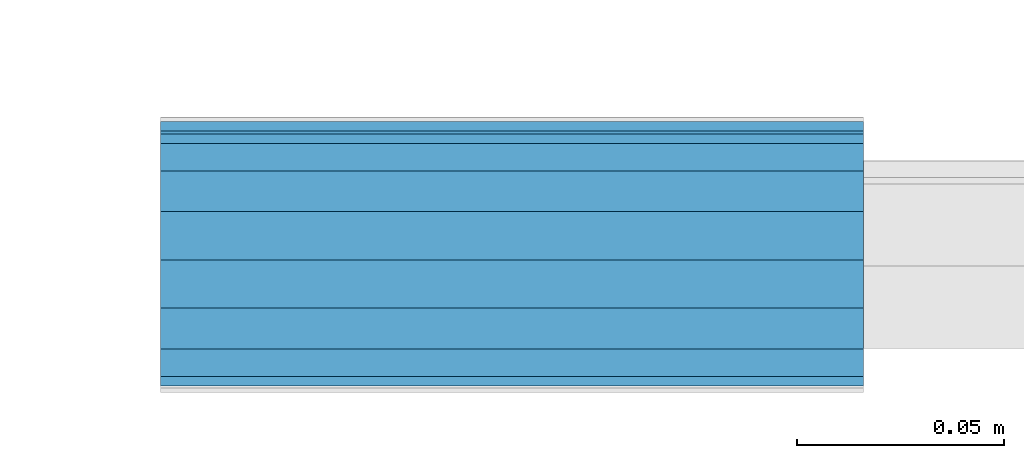
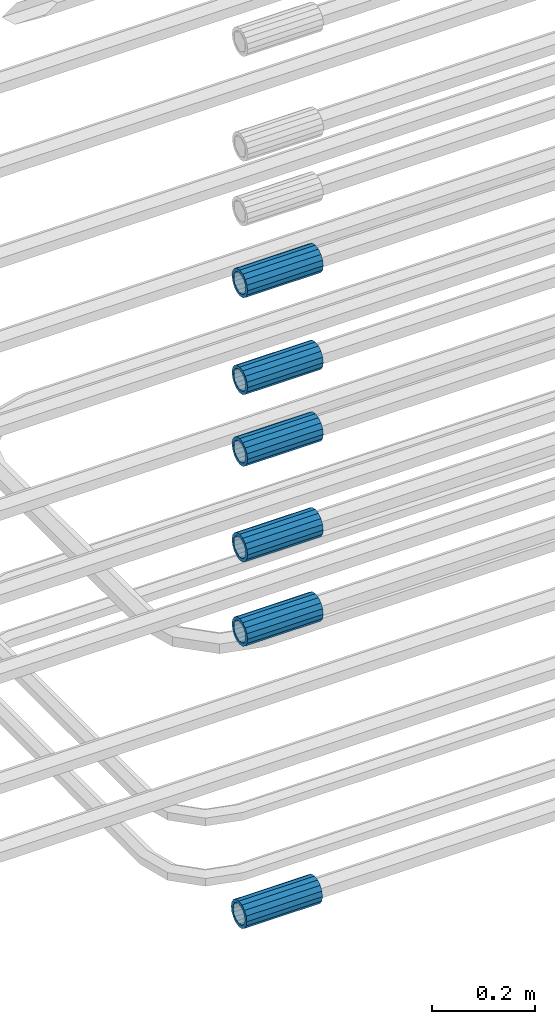
# One storey, part 4 of 119: 6 beams.
"""IFC2X3 building model written with IfcOpenShell, lengths in millimetres."""

from ifc_helpers import new_model, si_unit, frame, origin_with_axes, place, context, subcontext, project, spatial, faceted_brep, material, type_object, element, save


model = new_model("IFC2X3")

# Units and contexts
model_context = context("Model", 3, precision=1e-05, world=origin_with_axes())
body_context = subcontext(model_context, "Body", "Model", "MODEL_VIEW")
ifc_project = project(units=[si_unit("LENGTHUNIT", "METRE", prefix="MILLI"), si_unit("AREAUNIT", "SQUARE_METRE"), si_unit("VOLUMEUNIT", "CUBIC_METRE"), si_unit("MASSUNIT", "GRAM", prefix="KILO"), si_unit("TIMEUNIT", "SECOND"), si_unit("PLANEANGLEUNIT", "RADIAN"), si_unit("SOLIDANGLEUNIT", "STERADIAN"), si_unit("THERMODYNAMICTEMPERATUREUNIT", "DEGREE_CELSIUS"), si_unit("LUMINOUSINTENSITYUNIT", "LUMEN")], contexts=[model_context])

# Site, building, storey
site_placement = place(None, origin_with_axes())
site = spatial("IfcSite", under=ifc_project, at=site_placement, CompositionType="ELEMENT")
building_placement = place(site_placement, origin_with_axes())
building = spatial("IfcBuilding", under=site, at=building_placement, Name="Undefined", CompositionType="ELEMENT")
storey_placement = place(building_placement, origin_with_axes())
storey = spatial("IfcBuildingStorey", under=building, at=storey_placement, Name="Undefined", CompositionType="ELEMENT", Elevation=0.0)

# Beams
ifc_material = material(Name="STEEL/S275")
beam_type = type_object("IfcBeamType", PredefinedType="NOTDEFINED")
beam_1_placement = place(storey_placement, frame((2029920.00007889, 6205101.97994599, 19088.9893060828), z_axis=(0.0, 0.0, 1.0), x_axis=(-0.99999999999998, 1.98000110685822e-07, 0.0)))
element("IfcBeam", 1, at=beam_1_placement, inside=storey, type_object=beam_type, material=ifc_material, Name="AG40N", context=body_context, shape_type="Brep", body=[
    faceted_brep([(1.62981450557709e-09, -23.4999999990687, 0.0), (7.45058059692383e-09, -21.7111690142192, 8.99306066057534), (170.000002125278, -21.711168999318, 8.99306066022245), (170.000002127141, -23.4999999844003, -3.66071617463604e-10), (4.65661287307739e-09, -16.6170093587134, 16.6170093578889), (170.000002122484, -16.6170093440451, 16.6170093575288), (1.86264514923096e-09, -8.99306066217832, 21.7111690140277), (170.000002118759, -8.99306064750999, 21.7111690136603), (2.3283064365387e-10, 9.31322574615479e-10, 23.5), (170.000002114102, 1.28056854009628e-08, 23.4999999996485), (-6.51925802230835e-09, 8.99306065868586, 21.7111690140241), (170.00000211224, 8.99306067335419, 21.7111690136639), (-7.45058059692383e-09, 16.6170093561523, 16.6170093578853), (170.000002109446, 16.6170093708206, 16.6170093575324), (-9.31322574615479e-09, 21.711169013055, 8.99306066057534), (170.000002108514, 21.7111690277234, 8.99306066022245), (-1.16415321826935e-09, 23.5000000009313, 0.0), (170.000002108514, 23.5000000144355, -3.66071617463604e-10), (-8.38190317153931e-09, 21.7111690151505, -8.99306066059444), (170.000002110377, 21.7111690300517, -8.9930606609546), (-5.58793544769287e-09, 16.6170093598776, -16.6170093579008), (170.000002113171, 16.6170093745459, -16.6170093582609), (-9.31322574615479e-10, 8.99306066334248, -21.7111690140396), (170.000002115965, 8.99306067801081, -21.7111690143961), (2.3283064365387e-10, 9.31322574615479e-10, -23.5), (170.00000211969, 1.7927959561348e-08, -23.5000000003843), (5.58793544769287e-09, -8.99306065752171, -21.7111690140396), (170.000002123415, -8.99306064285338, -21.7111690143961), (8.38190317153931e-09, -16.6170093549881, -16.6170093579008), (170.000002125278, -16.6170093403198, -16.6170093582646), (9.31322574615479e-09, -21.7111690121237, -8.99306066059444), (170.000002127141, -21.7111689972226, -8.9930606609546), (1.11758708953857e-08, -30.4999999990687, -9.54969436861575e-12), (1.30385160446167e-08, -28.1783257392235, -11.6718446871514), (170.000002129003, -28.1783257243223, -11.6718446875116), (170.000002129935, -30.4999999841675, -3.66071617463604e-10), (1.02445483207703e-08, -21.5667568228673, -21.5667568262129), (170.000002128072, -21.566756808199, -21.5667568265694), (7.45058059692383e-09, -11.6718446831219, -28.1783257416196), (170.000002125278, -11.6718446684536, -28.1783257419834), (3.72529029846191e-09, 3.95812094211578e-09, -30.5000000000277), (170.00000211969, 1.83936208486557e-08, -30.5000000003879), (-9.31322574615479e-10, 11.6718446905725, -28.1783257416232), (170.000002115965, 11.6718447052408, -28.1783257419797), (-6.51925802230835e-09, 21.5667568286881, -21.5667568262093), (170.000002110377, 21.5667568433564, -21.5667568265694), (-9.31322574615479e-09, 28.178325742716, -11.6718446871478), (170.000002108514, 28.1783257573843, -11.6718446875079), (-1.21071934700012e-08, 30.5, -5.91171556152403e-12), (170.000002106652, 30.5000000144355, -3.62433638656512e-10), (-1.21071934700012e-08, 28.1783257401548, 11.6718446871359), (170.00000210572, 28.1783257548232, 11.6718446867794), (-1.02445483207703e-08, 21.5667568240315, 21.5667568261974), (170.000002107583, 21.566756838467, 21.5667568258409), (-7.45058059692383e-09, 11.671844684286, 28.1783257416041), (170.000002110377, 11.6718446989544, 28.178325741244), (-2.79396772384644e-09, -2.56113708019257e-09, 30.5000000000159), (170.000002114102, 1.18743628263474e-08, 30.4999999996558), (1.86264514923096e-09, -11.6718446896411, 28.1783257416114), (170.000002118759, -11.67184467474, 28.178325741244), (7.45058059692383e-09, -21.5667568275239, 21.5667568261974), (170.000002123415, -21.5667568126228, 21.5667568258373), (1.02445483207703e-08, -28.1783257415518, 11.6718446871359), (170.000002127141, -28.1783257271163, 11.6718446867794)], [[[0, 1, 2, 3]], [[1, 4, 5, 2]], [[4, 6, 7, 5]], [[6, 8, 9, 7]], [[8, 10, 11, 9]], [[10, 12, 13, 11]], [[12, 14, 15, 13]], [[14, 16, 17, 15]], [[16, 18, 19, 17]], [[18, 20, 21, 19]], [[20, 22, 23, 21]], [[22, 24, 25, 23]], [[24, 26, 27, 25]], [[26, 28, 29, 27]], [[28, 30, 31, 29]], [[30, 0, 3, 31]], [[32, 33, 34, 35]], [[33, 36, 37, 34]], [[36, 38, 39, 37]], [[38, 40, 41, 39]], [[40, 42, 43, 41]], [[42, 44, 45, 43]], [[44, 46, 47, 45]], [[46, 48, 49, 47]], [[48, 50, 51, 49]], [[50, 52, 53, 51]], [[52, 54, 55, 53]], [[54, 56, 57, 55]], [[56, 58, 59, 57]], [[58, 60, 61, 59]], [[60, 62, 63, 61]], [[62, 32, 35, 63]], [[37, 39, 41, 43, 45, 47, 49, 51, 53, 55, 57, 59, 61, 63, 35, 34], [5, 7, 9, 11, 13, 15, 17, 19, 21, 23, 25, 27, 29, 31, 3, 2]], [[62, 60, 58, 56, 54, 52, 50, 48, 46, 44, 42, 40, 38, 36, 33, 32], [30, 28, 26, 24, 22, 20, 18, 16, 14, 12, 10, 8, 6, 4, 1, 0]]]),
])
beam_2_placement = place(storey_placement, frame((2029920.00007889, 6205098.98994599, 19760.9893052823), z_axis=(0.0, 0.0, 1.0), x_axis=(-0.99999999999998, 1.98000110685822e-07, 0.0)))
element("IfcBeam", 2, at=beam_2_placement, inside=storey, type_object=beam_type, material=ifc_material, Name="AG40N", context=body_context, shape_type="Brep", body=[
    faceted_brep([(1.62981450557709e-09, -23.4999999990687, 0.0), (7.45058059692383e-09, -21.7111690142192, 8.99306066057534), (170.000002125278, -21.711168999318, 8.99306066022245), (170.000002127141, -23.4999999844003, -3.66071617463604e-10), (4.65661287307739e-09, -16.6170093587134, 16.6170093578889), (170.000002122484, -16.6170093440451, 16.6170093575288), (1.86264514923096e-09, -8.99306066217832, 21.7111690140277), (170.000002118759, -8.99306064750999, 21.7111690136603), (2.3283064365387e-10, 9.31322574615479e-10, 23.5), (170.000002114102, 1.28056854009628e-08, 23.4999999996485), (-6.51925802230835e-09, 8.99306065868586, 21.7111690140241), (170.00000211224, 8.99306067335419, 21.7111690136639), (-7.45058059692383e-09, 16.6170093561523, 16.6170093578853), (170.000002109446, 16.6170093708206, 16.6170093575324), (-9.31322574615479e-09, 21.711169013055, 8.99306066057534), (170.000002108514, 21.7111690277234, 8.99306066022245), (-1.16415321826935e-09, 23.5000000009313, 0.0), (170.000002108514, 23.5000000144355, -3.66071617463604e-10), (-8.38190317153931e-09, 21.7111690151505, -8.99306066059444), (170.000002110377, 21.7111690300517, -8.9930606609546), (-5.58793544769287e-09, 16.6170093598776, -16.6170093579008), (170.000002113171, 16.6170093745459, -16.6170093582609), (-9.31322574615479e-10, 8.99306066334248, -21.7111690140396), (170.000002115965, 8.99306067801081, -21.7111690143961), (2.3283064365387e-10, 9.31322574615479e-10, -23.5), (170.00000211969, 1.7927959561348e-08, -23.5000000003843), (5.58793544769287e-09, -8.99306065752171, -21.7111690140396), (170.000002123415, -8.99306064285338, -21.7111690143961), (8.38190317153931e-09, -16.6170093549881, -16.6170093579008), (170.000002125278, -16.6170093403198, -16.6170093582646), (9.31322574615479e-09, -21.7111690121237, -8.99306066059444), (170.000002127141, -21.7111689972226, -8.9930606609546), (1.11758708953857e-08, -30.4999999990687, -9.54969436861575e-12), (1.30385160446167e-08, -28.1783257392235, -11.6718446871514), (170.000002129003, -28.1783257243223, -11.6718446875116), (170.000002129935, -30.4999999841675, -3.66071617463604e-10), (1.02445483207703e-08, -21.5667568228673, -21.5667568262129), (170.000002128072, -21.566756808199, -21.5667568265694), (7.45058059692383e-09, -11.6718446831219, -28.1783257416196), (170.000002125278, -11.6718446684536, -28.1783257419834), (3.72529029846191e-09, 3.95812094211578e-09, -30.5000000000277), (170.00000211969, 1.83936208486557e-08, -30.5000000003879), (-9.31322574615479e-10, 11.6718446905725, -28.1783257416232), (170.000002115965, 11.6718447052408, -28.1783257419797), (-6.51925802230835e-09, 21.5667568286881, -21.5667568262093), (170.000002110377, 21.5667568433564, -21.5667568265694), (-9.31322574615479e-09, 28.178325742716, -11.6718446871478), (170.000002108514, 28.1783257573843, -11.6718446875079), (-1.21071934700012e-08, 30.5, -5.91171556152403e-12), (170.000002106652, 30.5000000144355, -3.62433638656512e-10), (-1.21071934700012e-08, 28.1783257401548, 11.6718446871359), (170.00000210572, 28.1783257548232, 11.6718446867794), (-1.02445483207703e-08, 21.5667568240315, 21.5667568261974), (170.000002107583, 21.566756838467, 21.5667568258409), (-7.45058059692383e-09, 11.671844684286, 28.1783257416041), (170.000002110377, 11.6718446989544, 28.178325741244), (-2.79396772384644e-09, -2.56113708019257e-09, 30.5000000000159), (170.000002114102, 1.18743628263474e-08, 30.4999999996558), (1.86264514923096e-09, -11.6718446896411, 28.1783257416114), (170.000002118759, -11.67184467474, 28.178325741244), (7.45058059692383e-09, -21.5667568275239, 21.5667568261974), (170.000002123415, -21.5667568126228, 21.5667568258373), (1.02445483207703e-08, -28.1783257415518, 11.6718446871359), (170.000002127141, -28.1783257271163, 11.6718446867794)], [[[0, 1, 2, 3]], [[1, 4, 5, 2]], [[4, 6, 7, 5]], [[6, 8, 9, 7]], [[8, 10, 11, 9]], [[10, 12, 13, 11]], [[12, 14, 15, 13]], [[14, 16, 17, 15]], [[16, 18, 19, 17]], [[18, 20, 21, 19]], [[20, 22, 23, 21]], [[22, 24, 25, 23]], [[24, 26, 27, 25]], [[26, 28, 29, 27]], [[28, 30, 31, 29]], [[30, 0, 3, 31]], [[32, 33, 34, 35]], [[33, 36, 37, 34]], [[36, 38, 39, 37]], [[38, 40, 41, 39]], [[40, 42, 43, 41]], [[42, 44, 45, 43]], [[44, 46, 47, 45]], [[46, 48, 49, 47]], [[48, 50, 51, 49]], [[50, 52, 53, 51]], [[52, 54, 55, 53]], [[54, 56, 57, 55]], [[56, 58, 59, 57]], [[58, 60, 61, 59]], [[60, 62, 63, 61]], [[62, 32, 35, 63]], [[37, 39, 41, 43, 45, 47, 49, 51, 53, 55, 57, 59, 61, 63, 35, 34], [5, 7, 9, 11, 13, 15, 17, 19, 21, 23, 25, 27, 29, 31, 3, 2]], [[62, 60, 58, 56, 54, 52, 50, 48, 46, 44, 42, 40, 38, 36, 33, 32], [30, 28, 26, 24, 22, 20, 18, 16, 14, 12, 10, 8, 6, 4, 1, 0]]]),
])
beam_3_placement = place(storey_placement, frame((2029920.00007889, 6205098.98994599, 19960.9893052823), z_axis=(0.0, 0.0, 1.0), x_axis=(-0.99999999999998, 1.98000110685822e-07, 0.0)))
element("IfcBeam", 3, at=beam_3_placement, inside=storey, type_object=beam_type, material=ifc_material, Name="AG40N", context=body_context, shape_type="Brep", body=[
    faceted_brep([(1.62981450557709e-09, -23.4999999990687, 0.0), (7.45058059692383e-09, -21.7111690142192, 8.99306066057534), (170.000002125278, -21.711168999318, 8.99306066022245), (170.000002127141, -23.4999999844003, -3.66071617463604e-10), (4.65661287307739e-09, -16.6170093587134, 16.6170093578889), (170.000002122484, -16.6170093440451, 16.6170093575288), (1.86264514923096e-09, -8.99306066217832, 21.7111690140277), (170.000002118759, -8.99306064750999, 21.7111690136603), (2.3283064365387e-10, 9.31322574615479e-10, 23.5), (170.000002114102, 1.28056854009628e-08, 23.4999999996485), (-6.51925802230835e-09, 8.99306065868586, 21.7111690140241), (170.00000211224, 8.99306067335419, 21.7111690136639), (-7.45058059692383e-09, 16.6170093561523, 16.6170093578853), (170.000002109446, 16.6170093708206, 16.6170093575324), (-9.31322574615479e-09, 21.711169013055, 8.99306066057534), (170.000002108514, 21.7111690277234, 8.99306066022245), (-1.16415321826935e-09, 23.5000000009313, 0.0), (170.000002108514, 23.5000000144355, -3.66071617463604e-10), (-8.38190317153931e-09, 21.7111690151505, -8.99306066059444), (170.000002110377, 21.7111690300517, -8.9930606609546), (-5.58793544769287e-09, 16.6170093598776, -16.6170093579008), (170.000002113171, 16.6170093745459, -16.6170093582609), (-9.31322574615479e-10, 8.99306066334248, -21.7111690140396), (170.000002115965, 8.99306067801081, -21.7111690143961), (2.3283064365387e-10, 9.31322574615479e-10, -23.5), (170.00000211969, 1.7927959561348e-08, -23.5000000003843), (5.58793544769287e-09, -8.99306065752171, -21.7111690140396), (170.000002123415, -8.99306064285338, -21.7111690143961), (8.38190317153931e-09, -16.6170093549881, -16.6170093579008), (170.000002125278, -16.6170093403198, -16.6170093582646), (9.31322574615479e-09, -21.7111690121237, -8.99306066059444), (170.000002127141, -21.7111689972226, -8.9930606609546), (1.11758708953857e-08, -30.4999999990687, -9.54969436861575e-12), (1.30385160446167e-08, -28.1783257392235, -11.6718446871514), (170.000002129003, -28.1783257243223, -11.6718446875116), (170.000002129935, -30.4999999841675, -3.66071617463604e-10), (1.02445483207703e-08, -21.5667568228673, -21.5667568262129), (170.000002128072, -21.566756808199, -21.5667568265694), (7.45058059692383e-09, -11.6718446831219, -28.1783257416196), (170.000002125278, -11.6718446684536, -28.1783257419834), (3.72529029846191e-09, 3.95812094211578e-09, -30.5000000000277), (170.00000211969, 1.83936208486557e-08, -30.5000000003879), (-9.31322574615479e-10, 11.6718446905725, -28.1783257416232), (170.000002115965, 11.6718447052408, -28.1783257419797), (-6.51925802230835e-09, 21.5667568286881, -21.5667568262093), (170.000002110377, 21.5667568433564, -21.5667568265694), (-9.31322574615479e-09, 28.178325742716, -11.6718446871478), (170.000002108514, 28.1783257573843, -11.6718446875079), (-1.21071934700012e-08, 30.5, -5.91171556152403e-12), (170.000002106652, 30.5000000144355, -3.62433638656512e-10), (-1.21071934700012e-08, 28.1783257401548, 11.6718446871359), (170.00000210572, 28.1783257548232, 11.6718446867794), (-1.02445483207703e-08, 21.5667568240315, 21.5667568261974), (170.000002107583, 21.566756838467, 21.5667568258409), (-7.45058059692383e-09, 11.671844684286, 28.1783257416041), (170.000002110377, 11.6718446989544, 28.178325741244), (-2.79396772384644e-09, -2.56113708019257e-09, 30.5000000000159), (170.000002114102, 1.18743628263474e-08, 30.4999999996558), (1.86264514923096e-09, -11.6718446896411, 28.1783257416114), (170.000002118759, -11.67184467474, 28.178325741244), (7.45058059692383e-09, -21.5667568275239, 21.5667568261974), (170.000002123415, -21.5667568126228, 21.5667568258373), (1.02445483207703e-08, -28.1783257415518, 11.6718446871359), (170.000002127141, -28.1783257271163, 11.6718446867794)], [[[0, 1, 2, 3]], [[1, 4, 5, 2]], [[4, 6, 7, 5]], [[6, 8, 9, 7]], [[8, 10, 11, 9]], [[10, 12, 13, 11]], [[12, 14, 15, 13]], [[14, 16, 17, 15]], [[16, 18, 19, 17]], [[18, 20, 21, 19]], [[20, 22, 23, 21]], [[22, 24, 25, 23]], [[24, 26, 27, 25]], [[26, 28, 29, 27]], [[28, 30, 31, 29]], [[30, 0, 3, 31]], [[32, 33, 34, 35]], [[33, 36, 37, 34]], [[36, 38, 39, 37]], [[38, 40, 41, 39]], [[40, 42, 43, 41]], [[42, 44, 45, 43]], [[44, 46, 47, 45]], [[46, 48, 49, 47]], [[48, 50, 51, 49]], [[50, 52, 53, 51]], [[52, 54, 55, 53]], [[54, 56, 57, 55]], [[56, 58, 59, 57]], [[58, 60, 61, 59]], [[60, 62, 63, 61]], [[62, 32, 35, 63]], [[37, 39, 41, 43, 45, 47, 49, 51, 53, 55, 57, 59, 61, 63, 35, 34], [5, 7, 9, 11, 13, 15, 17, 19, 21, 23, 25, 27, 29, 31, 3, 2]], [[62, 60, 58, 56, 54, 52, 50, 48, 46, 44, 42, 40, 38, 36, 33, 32], [30, 28, 26, 24, 22, 20, 18, 16, 14, 12, 10, 8, 6, 4, 1, 0]]]),
])
beam_4_placement = place(storey_placement, frame((2029920.00007889, 6205098.98994599, 20187.9893052823), z_axis=(0.0, 0.0, 1.0), x_axis=(-0.99999999999998, 1.98000110685822e-07, 0.0)))
element("IfcBeam", 4, at=beam_4_placement, inside=storey, type_object=beam_type, material=ifc_material, Name="AG40N", context=body_context, shape_type="Brep", body=[
    faceted_brep([(1.62981450557709e-09, -23.4999999990687, 0.0), (7.45058059692383e-09, -21.7111690142192, 8.99306066057534), (170.000002125278, -21.711168999318, 8.99306066022245), (170.000002127141, -23.4999999844003, -3.66071617463604e-10), (4.65661287307739e-09, -16.6170093587134, 16.6170093578889), (170.000002122484, -16.6170093440451, 16.6170093575288), (1.86264514923096e-09, -8.99306066217832, 21.7111690140277), (170.000002118759, -8.99306064750999, 21.7111690136603), (2.3283064365387e-10, 9.31322574615479e-10, 23.5), (170.000002114102, 1.28056854009628e-08, 23.4999999996485), (-6.51925802230835e-09, 8.99306065868586, 21.7111690140241), (170.00000211224, 8.99306067335419, 21.7111690136639), (-7.45058059692383e-09, 16.6170093561523, 16.6170093578853), (170.000002109446, 16.6170093708206, 16.6170093575324), (-9.31322574615479e-09, 21.711169013055, 8.99306066057534), (170.000002108514, 21.7111690277234, 8.99306066022245), (-1.16415321826935e-09, 23.5000000009313, 0.0), (170.000002108514, 23.5000000144355, -3.66071617463604e-10), (-8.38190317153931e-09, 21.7111690151505, -8.99306066059444), (170.000002110377, 21.7111690300517, -8.9930606609546), (-5.58793544769287e-09, 16.6170093598776, -16.6170093579008), (170.000002113171, 16.6170093745459, -16.6170093582609), (-9.31322574615479e-10, 8.99306066334248, -21.7111690140396), (170.000002115965, 8.99306067801081, -21.7111690143961), (2.3283064365387e-10, 9.31322574615479e-10, -23.5), (170.00000211969, 1.7927959561348e-08, -23.5000000003843), (5.58793544769287e-09, -8.99306065752171, -21.7111690140396), (170.000002123415, -8.99306064285338, -21.7111690143961), (8.38190317153931e-09, -16.6170093549881, -16.6170093579008), (170.000002125278, -16.6170093403198, -16.6170093582646), (9.31322574615479e-09, -21.7111690121237, -8.99306066059444), (170.000002127141, -21.7111689972226, -8.9930606609546), (1.11758708953857e-08, -30.4999999990687, -9.54969436861575e-12), (1.30385160446167e-08, -28.1783257392235, -11.6718446871514), (170.000002129003, -28.1783257243223, -11.6718446875116), (170.000002129935, -30.4999999841675, -3.66071617463604e-10), (1.02445483207703e-08, -21.5667568228673, -21.5667568262129), (170.000002128072, -21.566756808199, -21.5667568265694), (7.45058059692383e-09, -11.6718446831219, -28.1783257416196), (170.000002125278, -11.6718446684536, -28.1783257419834), (3.72529029846191e-09, 3.95812094211578e-09, -30.5000000000277), (170.00000211969, 1.83936208486557e-08, -30.5000000003879), (-9.31322574615479e-10, 11.6718446905725, -28.1783257416232), (170.000002115965, 11.6718447052408, -28.1783257419797), (-6.51925802230835e-09, 21.5667568286881, -21.5667568262093), (170.000002110377, 21.5667568433564, -21.5667568265694), (-9.31322574615479e-09, 28.178325742716, -11.6718446871478), (170.000002108514, 28.1783257573843, -11.6718446875079), (-1.21071934700012e-08, 30.5, -5.91171556152403e-12), (170.000002106652, 30.5000000144355, -3.62433638656512e-10), (-1.21071934700012e-08, 28.1783257401548, 11.6718446871359), (170.00000210572, 28.1783257548232, 11.6718446867794), (-1.02445483207703e-08, 21.5667568240315, 21.5667568261974), (170.000002107583, 21.566756838467, 21.5667568258409), (-7.45058059692383e-09, 11.671844684286, 28.1783257416041), (170.000002110377, 11.6718446989544, 28.178325741244), (-2.79396772384644e-09, -2.56113708019257e-09, 30.5000000000159), (170.000002114102, 1.18743628263474e-08, 30.4999999996558), (1.86264514923096e-09, -11.6718446896411, 28.1783257416114), (170.000002118759, -11.67184467474, 28.178325741244), (7.45058059692383e-09, -21.5667568275239, 21.5667568261974), (170.000002123415, -21.5667568126228, 21.5667568258373), (1.02445483207703e-08, -28.1783257415518, 11.6718446871359), (170.000002127141, -28.1783257271163, 11.6718446867794)], [[[0, 1, 2, 3]], [[1, 4, 5, 2]], [[4, 6, 7, 5]], [[6, 8, 9, 7]], [[8, 10, 11, 9]], [[10, 12, 13, 11]], [[12, 14, 15, 13]], [[14, 16, 17, 15]], [[16, 18, 19, 17]], [[18, 20, 21, 19]], [[20, 22, 23, 21]], [[22, 24, 25, 23]], [[24, 26, 27, 25]], [[26, 28, 29, 27]], [[28, 30, 31, 29]], [[30, 0, 3, 31]], [[32, 33, 34, 35]], [[33, 36, 37, 34]], [[36, 38, 39, 37]], [[38, 40, 41, 39]], [[40, 42, 43, 41]], [[42, 44, 45, 43]], [[44, 46, 47, 45]], [[46, 48, 49, 47]], [[48, 50, 51, 49]], [[50, 52, 53, 51]], [[52, 54, 55, 53]], [[54, 56, 57, 55]], [[56, 58, 59, 57]], [[58, 60, 61, 59]], [[60, 62, 63, 61]], [[62, 32, 35, 63]], [[37, 39, 41, 43, 45, 47, 49, 51, 53, 55, 57, 59, 61, 63, 35, 34], [5, 7, 9, 11, 13, 15, 17, 19, 21, 23, 25, 27, 29, 31, 3, 2]], [[62, 60, 58, 56, 54, 52, 50, 48, 46, 44, 42, 40, 38, 36, 33, 32], [30, 28, 26, 24, 22, 20, 18, 16, 14, 12, 10, 8, 6, 4, 1, 0]]]),
])
beam_5_placement = place(storey_placement, frame((2029920.00007889, 6205098.98994599, 20357.9893052823), z_axis=(0.0, 0.0, 1.0), x_axis=(-0.99999999999998, 1.98000110685822e-07, 0.0)))
element("IfcBeam", 5, at=beam_5_placement, inside=storey, type_object=beam_type, material=ifc_material, Name="AG40N", context=body_context, shape_type="Brep", body=[
    faceted_brep([(1.62981450557709e-09, -23.4999999990687, 0.0), (7.45058059692383e-09, -21.7111690142192, 8.99306066057534), (170.000002125278, -21.711168999318, 8.99306066022245), (170.000002127141, -23.4999999844003, -3.66071617463604e-10), (4.65661287307739e-09, -16.6170093587134, 16.6170093578889), (170.000002122484, -16.6170093440451, 16.6170093575288), (1.86264514923096e-09, -8.99306066217832, 21.7111690140277), (170.000002118759, -8.99306064750999, 21.7111690136603), (2.3283064365387e-10, 9.31322574615479e-10, 23.5), (170.000002114102, 1.28056854009628e-08, 23.4999999996485), (-6.51925802230835e-09, 8.99306065868586, 21.7111690140241), (170.00000211224, 8.99306067335419, 21.7111690136639), (-7.45058059692383e-09, 16.6170093561523, 16.6170093578853), (170.000002109446, 16.6170093708206, 16.6170093575324), (-9.31322574615479e-09, 21.711169013055, 8.99306066057534), (170.000002108514, 21.7111690277234, 8.99306066022245), (-1.16415321826935e-09, 23.5000000009313, 0.0), (170.000002108514, 23.5000000144355, -3.66071617463604e-10), (-8.38190317153931e-09, 21.7111690151505, -8.99306066059444), (170.000002110377, 21.7111690300517, -8.9930606609546), (-5.58793544769287e-09, 16.6170093598776, -16.6170093579008), (170.000002113171, 16.6170093745459, -16.6170093582609), (-9.31322574615479e-10, 8.99306066334248, -21.7111690140396), (170.000002115965, 8.99306067801081, -21.7111690143961), (2.3283064365387e-10, 9.31322574615479e-10, -23.5), (170.00000211969, 1.7927959561348e-08, -23.5000000003843), (5.58793544769287e-09, -8.99306065752171, -21.7111690140396), (170.000002123415, -8.99306064285338, -21.7111690143961), (8.38190317153931e-09, -16.6170093549881, -16.6170093579008), (170.000002125278, -16.6170093403198, -16.6170093582646), (9.31322574615479e-09, -21.7111690121237, -8.99306066059444), (170.000002127141, -21.7111689972226, -8.9930606609546), (1.11758708953857e-08, -30.4999999990687, -9.54969436861575e-12), (1.30385160446167e-08, -28.1783257392235, -11.6718446871514), (170.000002129003, -28.1783257243223, -11.6718446875116), (170.000002129935, -30.4999999841675, -3.66071617463604e-10), (1.02445483207703e-08, -21.5667568228673, -21.5667568262129), (170.000002128072, -21.566756808199, -21.5667568265694), (7.45058059692383e-09, -11.6718446831219, -28.1783257416196), (170.000002125278, -11.6718446684536, -28.1783257419834), (3.72529029846191e-09, 3.95812094211578e-09, -30.5000000000277), (170.00000211969, 1.83936208486557e-08, -30.5000000003879), (-9.31322574615479e-10, 11.6718446905725, -28.1783257416232), (170.000002115965, 11.6718447052408, -28.1783257419797), (-6.51925802230835e-09, 21.5667568286881, -21.5667568262093), (170.000002110377, 21.5667568433564, -21.5667568265694), (-9.31322574615479e-09, 28.178325742716, -11.6718446871478), (170.000002108514, 28.1783257573843, -11.6718446875079), (-1.21071934700012e-08, 30.5, -5.91171556152403e-12), (170.000002106652, 30.5000000144355, -3.62433638656512e-10), (-1.21071934700012e-08, 28.1783257401548, 11.6718446871359), (170.00000210572, 28.1783257548232, 11.6718446867794), (-1.02445483207703e-08, 21.5667568240315, 21.5667568261974), (170.000002107583, 21.566756838467, 21.5667568258409), (-7.45058059692383e-09, 11.671844684286, 28.1783257416041), (170.000002110377, 11.6718446989544, 28.178325741244), (-2.79396772384644e-09, -2.56113708019257e-09, 30.5000000000159), (170.000002114102, 1.18743628263474e-08, 30.4999999996558), (1.86264514923096e-09, -11.6718446896411, 28.1783257416114), (170.000002118759, -11.67184467474, 28.178325741244), (7.45058059692383e-09, -21.5667568275239, 21.5667568261974), (170.000002123415, -21.5667568126228, 21.5667568258373), (1.02445483207703e-08, -28.1783257415518, 11.6718446871359), (170.000002127141, -28.1783257271163, 11.6718446867794)], [[[0, 1, 2, 3]], [[1, 4, 5, 2]], [[4, 6, 7, 5]], [[6, 8, 9, 7]], [[8, 10, 11, 9]], [[10, 12, 13, 11]], [[12, 14, 15, 13]], [[14, 16, 17, 15]], [[16, 18, 19, 17]], [[18, 20, 21, 19]], [[20, 22, 23, 21]], [[22, 24, 25, 23]], [[24, 26, 27, 25]], [[26, 28, 29, 27]], [[28, 30, 31, 29]], [[30, 0, 3, 31]], [[32, 33, 34, 35]], [[33, 36, 37, 34]], [[36, 38, 39, 37]], [[38, 40, 41, 39]], [[40, 42, 43, 41]], [[42, 44, 45, 43]], [[44, 46, 47, 45]], [[46, 48, 49, 47]], [[48, 50, 51, 49]], [[50, 52, 53, 51]], [[52, 54, 55, 53]], [[54, 56, 57, 55]], [[56, 58, 59, 57]], [[58, 60, 61, 59]], [[60, 62, 63, 61]], [[62, 32, 35, 63]], [[37, 39, 41, 43, 45, 47, 49, 51, 53, 55, 57, 59, 61, 63, 35, 34], [5, 7, 9, 11, 13, 15, 17, 19, 21, 23, 25, 27, 29, 31, 3, 2]], [[62, 60, 58, 56, 54, 52, 50, 48, 46, 44, 42, 40, 38, 36, 33, 32], [30, 28, 26, 24, 22, 20, 18, 16, 14, 12, 10, 8, 6, 4, 1, 0]]]),
])
beam_6_placement = place(storey_placement, frame((2029920.00007889, 6205098.98994599, 20587.9893052823), z_axis=(0.0, 0.0, 1.0), x_axis=(-0.99999999999998, 1.98000110685822e-07, 0.0)))
element("IfcBeam", 6, at=beam_6_placement, inside=storey, type_object=beam_type, material=ifc_material, Name="AG40N", context=body_context, shape_type="Brep", body=[
    faceted_brep([(1.62981450557709e-09, -23.4999999990687, 0.0), (7.45058059692383e-09, -21.7111690142192, 8.99306066057534), (170.000002125278, -21.711168999318, 8.99306066022245), (170.000002127141, -23.4999999844003, -3.66071617463604e-10), (4.65661287307739e-09, -16.6170093587134, 16.6170093578889), (170.000002122484, -16.6170093440451, 16.6170093575288), (1.86264514923096e-09, -8.99306066217832, 21.7111690140277), (170.000002118759, -8.99306064750999, 21.7111690136603), (2.3283064365387e-10, 9.31322574615479e-10, 23.5), (170.000002114102, 1.28056854009628e-08, 23.4999999996485), (-6.51925802230835e-09, 8.99306065868586, 21.7111690140241), (170.00000211224, 8.99306067335419, 21.7111690136639), (-7.45058059692383e-09, 16.6170093561523, 16.6170093578853), (170.000002109446, 16.6170093708206, 16.6170093575324), (-9.31322574615479e-09, 21.711169013055, 8.99306066057534), (170.000002108514, 21.7111690277234, 8.99306066022245), (-1.16415321826935e-09, 23.5000000009313, 0.0), (170.000002108514, 23.5000000144355, -3.66071617463604e-10), (-8.38190317153931e-09, 21.7111690151505, -8.99306066059444), (170.000002110377, 21.7111690300517, -8.9930606609546), (-5.58793544769287e-09, 16.6170093598776, -16.6170093579008), (170.000002113171, 16.6170093745459, -16.6170093582609), (-9.31322574615479e-10, 8.99306066334248, -21.7111690140396), (170.000002115965, 8.99306067801081, -21.7111690143961), (2.3283064365387e-10, 9.31322574615479e-10, -23.5), (170.00000211969, 1.7927959561348e-08, -23.5000000003843), (5.58793544769287e-09, -8.99306065752171, -21.7111690140396), (170.000002123415, -8.99306064285338, -21.7111690143961), (8.38190317153931e-09, -16.6170093549881, -16.6170093579008), (170.000002125278, -16.6170093403198, -16.6170093582646), (9.31322574615479e-09, -21.7111690121237, -8.99306066059444), (170.000002127141, -21.7111689972226, -8.9930606609546), (1.11758708953857e-08, -30.4999999990687, -9.54969436861575e-12), (1.30385160446167e-08, -28.1783257392235, -11.6718446871514), (170.000002129003, -28.1783257243223, -11.6718446875116), (170.000002129935, -30.4999999841675, -3.66071617463604e-10), (1.02445483207703e-08, -21.5667568228673, -21.5667568262129), (170.000002128072, -21.566756808199, -21.5667568265694), (7.45058059692383e-09, -11.6718446831219, -28.1783257416196), (170.000002125278, -11.6718446684536, -28.1783257419834), (3.72529029846191e-09, 3.95812094211578e-09, -30.5000000000277), (170.00000211969, 1.83936208486557e-08, -30.5000000003879), (-9.31322574615479e-10, 11.6718446905725, -28.1783257416232), (170.000002115965, 11.6718447052408, -28.1783257419797), (-6.51925802230835e-09, 21.5667568286881, -21.5667568262093), (170.000002110377, 21.5667568433564, -21.5667568265694), (-9.31322574615479e-09, 28.178325742716, -11.6718446871478), (170.000002108514, 28.1783257573843, -11.6718446875079), (-1.21071934700012e-08, 30.5, -5.91171556152403e-12), (170.000002106652, 30.5000000144355, -3.62433638656512e-10), (-1.21071934700012e-08, 28.1783257401548, 11.6718446871359), (170.00000210572, 28.1783257548232, 11.6718446867794), (-1.02445483207703e-08, 21.5667568240315, 21.5667568261974), (170.000002107583, 21.566756838467, 21.5667568258409), (-7.45058059692383e-09, 11.671844684286, 28.1783257416041), (170.000002110377, 11.6718446989544, 28.178325741244), (-2.79396772384644e-09, -2.56113708019257e-09, 30.5000000000159), (170.000002114102, 1.18743628263474e-08, 30.4999999996558), (1.86264514923096e-09, -11.6718446896411, 28.1783257416114), (170.000002118759, -11.67184467474, 28.178325741244), (7.45058059692383e-09, -21.5667568275239, 21.5667568261974), (170.000002123415, -21.5667568126228, 21.5667568258373), (1.02445483207703e-08, -28.1783257415518, 11.6718446871359), (170.000002127141, -28.1783257271163, 11.6718446867794)], [[[0, 1, 2, 3]], [[1, 4, 5, 2]], [[4, 6, 7, 5]], [[6, 8, 9, 7]], [[8, 10, 11, 9]], [[10, 12, 13, 11]], [[12, 14, 15, 13]], [[14, 16, 17, 15]], [[16, 18, 19, 17]], [[18, 20, 21, 19]], [[20, 22, 23, 21]], [[22, 24, 25, 23]], [[24, 26, 27, 25]], [[26, 28, 29, 27]], [[28, 30, 31, 29]], [[30, 0, 3, 31]], [[32, 33, 34, 35]], [[33, 36, 37, 34]], [[36, 38, 39, 37]], [[38, 40, 41, 39]], [[40, 42, 43, 41]], [[42, 44, 45, 43]], [[44, 46, 47, 45]], [[46, 48, 49, 47]], [[48, 50, 51, 49]], [[50, 52, 53, 51]], [[52, 54, 55, 53]], [[54, 56, 57, 55]], [[56, 58, 59, 57]], [[58, 60, 61, 59]], [[60, 62, 63, 61]], [[62, 32, 35, 63]], [[37, 39, 41, 43, 45, 47, 49, 51, 53, 55, 57, 59, 61, 63, 35, 34], [5, 7, 9, 11, 13, 15, 17, 19, 21, 23, 25, 27, 29, 31, 3, 2]], [[62, 60, 58, 56, 54, 52, 50, 48, 46, 44, 42, 40, 38, 36, 33, 32], [30, 28, 26, 24, 22, 20, 18, 16, 14, 12, 10, 8, 6, 4, 1, 0]]]),
])

save(model, "model.ifc")
